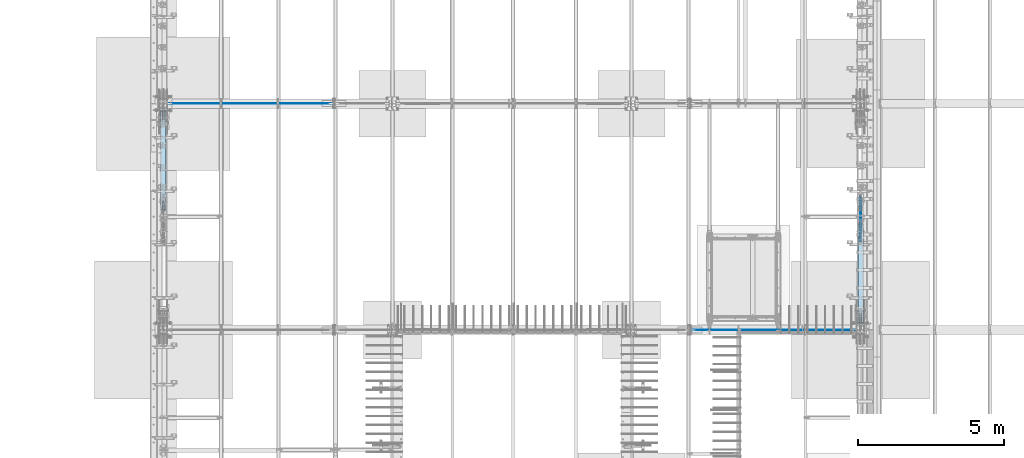
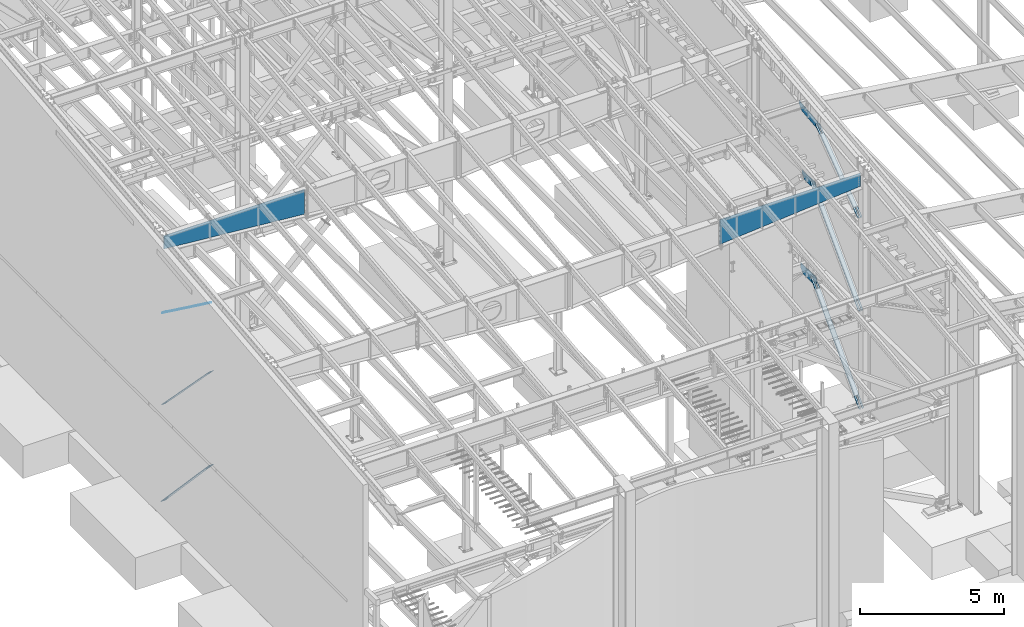
# One storey, part 971 of 1179: 11 plates, 11 elements without a shape of their own.
"""IFC2X3 building model written with IfcOpenShell, lengths in millimetres."""

from ifc_helpers import new_model, si_unit, frame, origin_with_axes, place, context, subcontext, project, spatial, faceted_brep, material, type_object, element, aggregate, save


model = new_model("IFC2X3")

# Units and contexts
model_context = context("Model", 3, precision=1e-05, world=origin_with_axes())
body_context = subcontext(model_context, "Body", "Model", "MODEL_VIEW")
ifc_project = project(units=[si_unit("LENGTHUNIT", "METRE", prefix="MILLI"), si_unit("AREAUNIT", "SQUARE_METRE"), si_unit("VOLUMEUNIT", "CUBIC_METRE"), si_unit("MASSUNIT", "GRAM", prefix="KILO"), si_unit("TIMEUNIT", "SECOND"), si_unit("PLANEANGLEUNIT", "RADIAN"), si_unit("SOLIDANGLEUNIT", "STERADIAN"), si_unit("THERMODYNAMICTEMPERATUREUNIT", "DEGREE_CELSIUS"), si_unit("LUMINOUSINTENSITYUNIT", "LUMEN")], contexts=[model_context])

# Site, building, storey
site_placement = place(None, origin_with_axes())
site = spatial("IfcSite", under=ifc_project, at=site_placement, CompositionType="ELEMENT")
building_placement = place(site_placement, origin_with_axes())
building = spatial("IfcBuilding", under=site, at=building_placement, Name="Undefined", CompositionType="ELEMENT")
storey_placement = place(building_placement, origin_with_axes())
storey = spatial("IfcBuildingStorey", under=building, at=storey_placement, Name="Undefined", CompositionType="ELEMENT", Elevation=0.0)

# Assembly, plate
assembly_1_placement = place(storey_placement, origin_with_axes())
assembly_1 = element("IfcElementAssembly", 1, at=assembly_1_placement, inside=storey, Name="BEAM", AssemblyPlace="NOTDEFINED", PredefinedType="RIGID_FRAME")
ifc_material_1 = material(Name="STEEL/A572-GR.50")
plate_type_1 = type_object("IfcPlateType", PredefinedType="NOTDEFINED")
plate_1_placement = place(assembly_1_placement, frame((24307.8, 14878.05, 7539.60905052728), z_axis=(0.0, 1.0, 0.0), x_axis=(0.0, 0.0, 1.0)))
plate_1 = element("IfcPlate", 2, at=plate_1_placement, type_object=plate_type_1, material=ifc_material_1, Name="PLATE", context=body_context, shape_type="Brep", body=[
    faceted_brep([(0.0, -9.52499999999964, 0.0), (-186.309050642565, -9.52500000000146, 190.890420911079), (-186.309050642565, 9.52500000000146, 190.890420911079), (0.0, 9.52499999999964, 0.0), (-186.30905049287, -9.52500000000146, 482.600000483581), (-186.30905049287, 9.52500000000146, 482.600000483581), (-186.309050331894, -9.52500000000146, 761.609579128339), (-186.309050331894, 9.52500000000146, 761.609579128339), (6.76212039252277e-07, -9.52500000000146, 952.499999997119), (6.76212039252277e-07, 9.52500000000146, 952.499999997119), (143.89094955044, -9.52500000000146, 952.500000233997), (143.89094955044, 9.52500000000146, 952.500000233997), (143.890949095251, -9.52500000000146, 0.0), (143.890949095251, 9.52500000000146, 0.0)], [[[0, 1, 2, 3]], [[1, 4, 5, 2]], [[4, 6, 7, 5]], [[6, 8, 9, 7]], [[8, 10, 11, 9]], [[10, 12, 13, 11]], [[12, 0, 3, 13]], [[5, 7, 9, 11, 13, 3, 2]], [[12, 10, 8, 6, 4, 1, 0]]]),
])
aggregate(assembly_1, [plate_1])

assembly_2_placement = place(storey_placement, origin_with_axes())
assembly_2 = element("IfcElementAssembly", 3, at=assembly_2_placement, inside=storey, Name="CB", AssemblyPlace="NOTDEFINED", PredefinedType="RIGID_FRAME")
ifc_material_2 = material(Name="STEEL/A36")
plate_type_2 = type_object("IfcPlateType", PredefinedType="NOTDEFINED")
plate_2_placement = place(assembly_2_placement, frame((341.312500000002, 18933.9952053959, 8077.03322244691), z_axis=(0.0, -0.806043266248582, 0.591856615182527), x_axis=(1.0, 0.0, 0.0)))
plate_2 = element("IfcPlate", 4, at=plate_2_placement, type_object=plate_type_2, material=ifc_material_2, Name="CB", context=body_context, shape_type="Brep", body=[
    faceted_brep([(0.0, -6.34999999991851, 71.4374999999018), (0.0, -6.35000000333093, 3879.50747780775), (0.0, 6.34999999666252, 3879.50747780777), (0.0, 6.35000000007858, 71.4374999999018), (5.43785589622496, -6.3500000033564, 3906.84542550735), (5.43785589622496, 6.34999999664069, 3906.84542550736), (20.923559318986, -6.35000000337459, 3930.0214184888), (20.923559318986, 6.34999999661886, 3930.02141848881), (44.0995523004189, -6.3500000033855, 3945.50712191157), (44.0995523004189, 6.34999999660431, 3945.50712191158), (71.4375, -6.35000000339278, 3950.9449778078), (71.4375, 6.34999999660431, 3950.94497780781), (71.4375, -6.35000000303262, 3531.22248890774), (71.4375, 6.34999999696083, 3531.22248890776), (109.537499999999, -6.35000000303262, 3531.22248890774), (109.537499999999, 6.34999999696083, 3531.22248890776), (109.537499999999, -6.35000000339278, 3950.9449778078), (109.537499999999, 6.34999999660431, 3950.94497780781), (136.87544769958, -6.3500000033855, 3945.50712191157), (136.87544769958, 6.34999999660431, 3945.50712191158), (160.051440681012, -6.35000000337459, 3930.0214184888), (160.051440681012, 6.34999999661886, 3930.02141848881), (175.537144103774, -6.3500000033564, 3906.84542550735), (175.537144103774, 6.34999999664069, 3906.84542550736), (180.974999999999, -6.35000000333093, 3879.50747780775), (180.974999999999, 6.34999999666252, 3879.50747780777), (180.975000000006, -6.34999999991851, 71.4374999999018), (180.975000000006, 6.35000000007858, 71.4374999999018), (175.537144103779, -6.34999999995125, 44.0995523003585), (175.537144103779, 6.35000000004584, 44.0995523003585), (160.051440681018, -6.34999999997672, 20.9235593189551), (160.051440681018, 6.35000000002401, 20.9235593189587), (136.875447699589, -6.34999999999491, 5.43785589621984), (136.875447699589, 6.35000000000218, 5.43785589621621), (109.537500000006, -6.34999999999854, 3.63797880709171e-12), (109.537500000006, 6.35000000000218, 0.0), (109.537500000006, -6.34999999953288, 419.722488898133), (109.537500000006, 6.35000000046784, 419.722488898133), (71.4375, -6.34999999953288, 419.722488898133), (71.4375, 6.35000000046784, 419.722488898133), (71.4375, -6.34999999999854, 3.63797880709171e-12), (71.4375, 6.35000000000218, 0.0), (44.0995523004167, -6.34999999999491, 5.43785589621984), (44.0995523004167, 6.35000000000218, 5.43785589621621), (20.9235593189878, -6.34999999997672, 20.9235593189551), (20.9235593189878, 6.35000000002401, 20.9235593189587), (5.43785589622712, -6.34999999995125, 44.0995523003585), (5.43785589622712, 6.35000000004584, 44.0995523003585)], [[[0, 1, 2, 3]], [[1, 4, 5, 2]], [[4, 6, 7, 5]], [[6, 8, 9, 7]], [[8, 10, 11, 9]], [[10, 12, 13, 11]], [[12, 14, 15, 13]], [[14, 16, 17, 15]], [[16, 18, 19, 17]], [[18, 20, 21, 19]], [[20, 22, 23, 21]], [[22, 24, 25, 23]], [[24, 26, 27, 25]], [[26, 28, 29, 27]], [[28, 30, 31, 29]], [[30, 32, 33, 31]], [[32, 34, 35, 33]], [[34, 36, 37, 35]], [[36, 38, 39, 37]], [[38, 40, 41, 39]], [[40, 42, 43, 41]], [[42, 44, 45, 43]], [[44, 46, 47, 45]], [[46, 0, 3, 47]], [[5, 7, 9, 11, 13, 15, 17, 19, 21, 23, 25, 27, 29, 31, 33, 35, 37, 39, 41, 43, 45, 47, 3, 2]], [[46, 44, 42, 40, 38, 36, 34, 32, 30, 28, 26, 24, 22, 20, 18, 16, 14, 12, 10, 8, 6, 4, 1, 0]]]),
])
aggregate(assembly_2, [plate_2])

assembly_3_placement = place(storey_placement, origin_with_axes())
assembly_3 = element("IfcElementAssembly", 5, at=assembly_3_placement, inside=storey, Name="CB", AssemblyPlace="NOTDEFINED", PredefinedType="RIGID_FRAME")
plate_3_placement = place(assembly_3_placement, frame((24398.2875, 11774.6044507526, 8077.03369074042), z_axis=(0.0, 0.806042322895357, 0.591857899923163), x_axis=(-1.0, 0.0, 0.0)))
plate_3 = element("IfcPlate", 6, at=plate_3_placement, type_object=plate_type_2, material=ifc_material_2, Name="CB", context=body_context, shape_type="Brep", body=[
    faceted_brep([(0.0, -6.34999999991851, 71.4374999999018), (0.0, -6.34999999920291, 3657.25747777707), (0.0, 6.3500000008051, 3657.25747777707), (0.0, 6.35000000007858, 71.4374999999018), (5.43785589622496, -6.34999999919745, 3684.59542547663), (5.43785589622496, 6.35000000080873, 3684.59542547663), (20.923559318986, -6.34999999919199, 3707.77141845805), (20.923559318986, 6.35000000081419, 3707.77141845804), (44.0995523004189, -6.34999999919017, 3723.2571218808), (44.0995523004189, 6.35000000081783, 3723.25712188079), (71.4375, -6.34999999918654, 3728.69497777702), (71.4375, 6.35000000081965, 3728.69497777701), (71.4375, -6.34999999927476, 3321.6724888803), (71.4375, 6.3500000007287, 3321.67248888029), (109.537499999999, -6.34999999927476, 3321.6724888803), (109.537499999999, 6.3500000007287, 3321.67248888029), (109.537499999999, -6.34999999918654, 3728.69497777702), (109.537499999999, 6.35000000081965, 3728.69497777701), (136.87544769958, -6.34999999919017, 3723.2571218808), (136.87544769958, 6.35000000081783, 3723.25712188079), (160.051440681013, -6.34999999919199, 3707.77141845805), (160.051440681013, 6.35000000081419, 3707.77141845804), (175.537144103774, -6.34999999919745, 3684.59542547663), (175.537144103774, 6.35000000080873, 3684.59542547663), (180.974999999999, -6.34999999920291, 3657.25747777707), (180.974999999999, 6.3500000008051, 3657.25747777707), (180.975000000006, -6.34999999991851, 71.4374999999018), (180.975000000006, 6.35000000007858, 71.4374999999018), (175.537144103779, -6.34999999995125, 44.0995523003585), (175.537144103779, 6.35000000004584, 44.0995523003585), (160.051440681018, -6.34999999997672, 20.9235593189551), (160.051440681018, 6.35000000002401, 20.9235593189587), (136.875447699589, -6.34999999999491, 5.43785589621984), (136.875447699589, 6.35000000000218, 5.43785589621621), (109.537500000006, -6.34999999999854, 3.63797880709171e-12), (109.537500000006, 6.35000000000218, 0.0), (109.537499999999, -6.34999999991595, 407.022488896726), (109.537499999999, 6.35000000009114, 407.022488896719), (71.4375, -6.34999999991595, 407.022488896726), (71.4375, 6.35000000009114, 407.022488896719), (71.4375, -6.34999999999854, 3.63797880709171e-12), (71.4375, 6.35000000000218, 0.0), (44.0995523004167, -6.34999999999491, 5.43785589621984), (44.0995523004167, 6.35000000000218, 5.43785589621621), (20.9235593189878, -6.34999999997672, 20.9235593189551), (20.9235593189878, 6.35000000002401, 20.9235593189587), (5.43785589622712, -6.34999999995125, 44.0995523003585), (5.43785589622712, 6.35000000004584, 44.0995523003585)], [[[0, 1, 2, 3]], [[1, 4, 5, 2]], [[4, 6, 7, 5]], [[6, 8, 9, 7]], [[8, 10, 11, 9]], [[10, 12, 13, 11]], [[12, 14, 15, 13]], [[14, 16, 17, 15]], [[16, 18, 19, 17]], [[18, 20, 21, 19]], [[20, 22, 23, 21]], [[22, 24, 25, 23]], [[24, 26, 27, 25]], [[26, 28, 29, 27]], [[28, 30, 31, 29]], [[30, 32, 33, 31]], [[32, 34, 35, 33]], [[34, 36, 37, 35]], [[36, 38, 39, 37]], [[38, 40, 41, 39]], [[40, 42, 43, 41]], [[42, 44, 45, 43]], [[44, 46, 47, 45]], [[46, 0, 3, 47]], [[5, 7, 9, 11, 13, 15, 17, 19, 21, 23, 25, 27, 29, 31, 33, 35, 37, 39, 41, 43, 45, 47, 3, 2]], [[46, 44, 42, 40, 38, 36, 34, 32, 30, 28, 26, 24, 22, 20, 18, 16, 14, 12, 10, 8, 6, 4, 1, 0]]]),
])
aggregate(assembly_3, [plate_3])

assembly_4_placement = place(storey_placement, origin_with_axes())
assembly_4 = element("IfcElementAssembly", 7, at=assembly_4_placement, inside=storey, Name="CB", AssemblyPlace="NOTDEFINED", PredefinedType="RIGID_FRAME")
plate_type_3 = type_object("IfcPlateType", PredefinedType="NOTDEFINED")
plate_4_placement = place(assembly_4_placement, frame((338.137500000002, 18978.4459530821, 4148.035704534), z_axis=(0.0, -0.69846692303685, 0.715642339037759), x_axis=(1.0, 0.0, 0.0)))
plate_4 = element("IfcPlate", 8, at=plate_4_placement, type_object=plate_type_3, material=ifc_material_2, Name="CB", context=body_context, shape_type="Brep", body=[
    faceted_brep([(0.0, -9.52500000000691, 71.4375), (0.0, -9.52499999965221, 4791.84892355422), (0.0, 9.52500000033979, 4791.84892355423), (0.0, 9.52500000000327, 71.4374999999909), (5.43785589622496, -9.52499999964857, 4819.1868712538), (5.43785589622496, 9.52500000034343, 4819.18687125381), (20.923559318986, -9.52499999964857, 4842.36286423524), (20.923559318986, 9.52500000034343, 4842.36286423525), (44.0995523004189, -9.52499999964493, 4857.848567658), (44.0995523004189, 9.52500000034343, 4857.84856765801), (71.4375, -9.52499999964493, 4863.28642355423), (71.4375, 9.52500000034706, 4863.28642355424), (71.4375, -9.52499999967404, 4441.70468275449), (71.4375, 9.52500000031432, 4441.7046827545), (115.8875, -9.52499999967404, 4441.70468275449), (115.8875, 9.52500000031432, 4441.7046827545), (115.8875, -9.52499999964493, 4863.28642355423), (115.8875, 9.52500000034706, 4863.28642355424), (143.225447699581, -9.52499999964493, 4857.848567658), (143.225447699581, 9.52500000034343, 4857.84856765801), (166.401440681014, -9.52499999964857, 4842.36286423524), (166.401440681014, 9.52500000034343, 4842.36286423525), (181.887144103775, -9.52499999964857, 4819.1868712538), (181.887144103775, 9.52500000034343, 4819.18687125381), (187.325, -9.52499999965221, 4791.84892355422), (187.325, 9.52500000033979, 4791.84892355423), (187.324999999997, -9.52500000000691, 71.4375), (187.324999999997, 9.52500000000327, 71.4374999999909), (181.88714410377, -9.52500000000691, 44.0995523004203), (181.88714410377, 9.52500000000509, 44.0995523004112), (166.401440681009, -9.52500000000691, 20.9235593189915), (166.401440681009, 9.52500000000509, 20.9235593189787), (143.22544769958, -9.52500000000327, 5.43785589623076), (143.22544769958, 9.52500000000509, 5.43785589621621), (115.887499999997, -9.52500000000509, 5.45696821063757e-12), (115.887499999997, 9.52500000000691, -7.27595761418343e-12), (115.887499999997, -9.52500000001783, 421.581740798863), (115.887499999997, 9.52499999999418, 421.581740798851), (71.4375, -9.52500000001783, 421.581740798863), (71.4375, 9.52499999999418, 421.581740798851), (71.4375, -9.52500000000509, 5.45696821063757e-12), (71.4375, 9.52500000000691, -7.27595761418343e-12), (44.0995523004167, -9.52500000000327, 5.43785589623076), (44.0995523004167, 9.52500000000509, 5.43785589621621), (20.9235593189878, -9.52500000000691, 20.9235593189915), (20.9235593189878, 9.52500000000509, 20.9235593189787), (5.43785589622712, -9.52500000000691, 44.0995523004203), (5.43785589622712, 9.52500000000509, 44.0995523004112)], [[[0, 1, 2, 3]], [[1, 4, 5, 2]], [[4, 6, 7, 5]], [[6, 8, 9, 7]], [[8, 10, 11, 9]], [[10, 12, 13, 11]], [[12, 14, 15, 13]], [[14, 16, 17, 15]], [[16, 18, 19, 17]], [[18, 20, 21, 19]], [[20, 22, 23, 21]], [[22, 24, 25, 23]], [[24, 26, 27, 25]], [[26, 28, 29, 27]], [[28, 30, 31, 29]], [[30, 32, 33, 31]], [[32, 34, 35, 33]], [[34, 36, 37, 35]], [[36, 38, 39, 37]], [[38, 40, 41, 39]], [[40, 42, 43, 41]], [[42, 44, 45, 43]], [[44, 46, 47, 45]], [[46, 0, 3, 47]], [[5, 7, 9, 11, 13, 15, 17, 19, 21, 23, 25, 27, 29, 31, 33, 35, 37, 39, 41, 43, 45, 47, 3, 2]], [[46, 44, 42, 40, 38, 36, 34, 32, 30, 28, 26, 24, 22, 20, 18, 16, 14, 12, 10, 8, 6, 4, 1, 0]]]),
])
aggregate(assembly_4, [plate_4])

assembly_5_placement = place(storey_placement, origin_with_axes())
assembly_5 = element("IfcElementAssembly", 9, at=assembly_5_placement, inside=storey, Name="CB", AssemblyPlace="NOTDEFINED", PredefinedType="RIGID_FRAME")
plate_5_placement = place(assembly_5_placement, frame((24401.4625, 11730.1540473062, 4148.03570415857), z_axis=(0.0, 0.698466923036852, 0.715642339037758), x_axis=(-1.0, 0.0, 0.0)))
plate_5 = element("IfcPlate", 10, at=plate_5_placement, type_object=plate_type_3, material=ifc_material_2, Name="CB", context=body_context, shape_type="Brep", body=[
    faceted_brep([(0.0, -9.52500000000691, 71.4375), (0.0, -9.52499999865904, 4791.85938084953), (0.0, 9.52500000133659, 4791.85938084954), (0.0, 9.52500000000327, 71.4374999999909), (5.43785589622348, -9.52499999864995, 4819.19732854909), (5.43785589622348, 9.52500000134387, 4819.1973285491), (20.9235593189878, -9.52499999864358, 4842.37332153051), (20.9235593189878, 9.52500000135024, 4842.37332153051), (44.0995523004203, -9.52499999863994, 4857.85902495325), (44.0995523004203, 9.5250000013566, 4857.85902495326), (71.4375, -9.52499999863721, 4863.29688084947), (71.4375, 9.52500000135842, 4863.29688084948), (71.4375, -9.52499999875545, 4441.71514005305), (71.4375, 9.5250000012411, 4441.71514005306), (115.887499999997, -9.52499999875545, 4441.71514005305), (115.887499999997, 9.5250000012411, 4441.71514005306), (115.887499999997, -9.52499999863721, 4863.29688084947), (115.887499999997, 9.52500000135842, 4863.29688084948), (143.225447699577, -9.52499999863994, 4857.85902495325), (143.225447699577, 9.5250000013566, 4857.85902495326), (166.401440681009, -9.52499999864358, 4842.37332153051), (166.401440681009, 9.52500000135024, 4842.37332153051), (181.887144103774, -9.52499999864995, 4819.19732854909), (181.887144103774, 9.52500000134387, 4819.1973285491), (187.324999999997, -9.52499999865904, 4791.85938084953), (187.324999999997, 9.52500000133659, 4791.85938084954), (187.324999999997, -9.52500000000691, 71.4375), (187.324999999997, 9.52500000000327, 71.4374999999909), (181.88714410377, -9.52500000000691, 44.0995523004203), (181.88714410377, 9.52500000000509, 44.0995523004112), (166.401440681009, -9.52500000000691, 20.9235593189915), (166.401440681009, 9.52500000000509, 20.9235593189787), (143.22544769958, -9.52500000000327, 5.43785589623076), (143.22544769958, 9.52500000000509, 5.43785589621621), (115.887499999997, -9.52500000000509, 5.45696821063757e-12), (115.887499999997, 9.52500000000691, -7.27595761418343e-12), (115.887499999997, -9.52500000001783, 421.581740798863), (115.887499999997, 9.52499999999418, 421.581740798851), (71.4375, -9.52500000001783, 421.581740798863), (71.4375, 9.52499999999418, 421.581740798851), (71.4375, -9.52500000000509, 5.45696821063757e-12), (71.4375, 9.52500000000691, -7.27595761418343e-12), (44.0995523004167, -9.52500000000327, 5.43785589623076), (44.0995523004167, 9.52500000000509, 5.43785589621621), (20.9235593189878, -9.52500000000691, 20.9235593189915), (20.9235593189878, 9.52500000000509, 20.9235593189787), (5.43785589622712, -9.52500000000691, 44.0995523004203), (5.43785589622712, 9.52500000000509, 44.0995523004112)], [[[0, 1, 2, 3]], [[1, 4, 5, 2]], [[4, 6, 7, 5]], [[6, 8, 9, 7]], [[8, 10, 11, 9]], [[10, 12, 13, 11]], [[12, 14, 15, 13]], [[14, 16, 17, 15]], [[16, 18, 19, 17]], [[18, 20, 21, 19]], [[20, 22, 23, 21]], [[22, 24, 25, 23]], [[24, 26, 27, 25]], [[26, 28, 29, 27]], [[28, 30, 31, 29]], [[30, 32, 33, 31]], [[32, 34, 35, 33]], [[34, 36, 37, 35]], [[36, 38, 39, 37]], [[38, 40, 41, 39]], [[40, 42, 43, 41]], [[42, 44, 45, 43]], [[44, 46, 47, 45]], [[46, 0, 3, 47]], [[5, 7, 9, 11, 13, 15, 17, 19, 21, 23, 25, 27, 29, 31, 33, 35, 37, 39, 41, 43, 45, 47, 3, 2]], [[46, 44, 42, 40, 38, 36, 34, 32, 30, 28, 26, 24, 22, 20, 18, 16, 14, 12, 10, 8, 6, 4, 1, 0]]]),
])
aggregate(assembly_5, [plate_5])

assembly_6_placement = place(storey_placement, origin_with_axes())
assembly_6 = element("IfcElementAssembly", 11, at=assembly_6_placement, inside=storey, Name="BEAM", AssemblyPlace="NOTDEFINED", PredefinedType="RIGID_FRAME")
plate_type_4 = type_object("IfcPlateType", PredefinedType="NOTDEFINED")
plate_6_placement = place(assembly_6_placement, frame((24307.8, 14793.6602577624, 3473.77993843472), z_axis=(0.0, 1.0, 0.0), x_axis=(0.0, 0.0, 1.0)))
plate_6 = element("IfcPlate", 12, at=plate_6_placement, type_object=plate_type_4, material=ifc_material_1, Name="PLATE", context=body_context, shape_type="Brep", body=[
    faceted_brep([(0.0, -12.7, 0.0), (-165.530801027491, -12.7, 175.571193903201), (-165.530801027491, 12.7, 175.571193903201), (0.0, 12.7, 0.0), (-165.530801027491, -12.7, 566.989741928064), (-165.530801027491, 12.7, 566.989741928064), (-165.530801027491, -12.7, 945.708290572049), (-165.530801027491, 12.7, 945.708290572049), (-3.09023562294897e-07, -12.7, 1121.27948414748), (-3.09023562294897e-07, 12.7, 1121.27948414748), (209.22006156528, -12.7, 1121.27948414748), (209.22006156528, 12.7, 1121.27948414748), (209.22006156528, -12.7, -3.63797880709171e-12), (209.22006156528, 12.7, -3.63797880709171e-12)], [[[0, 1, 2, 3]], [[1, 4, 5, 2]], [[4, 6, 7, 5]], [[6, 8, 9, 7]], [[8, 10, 11, 9]], [[10, 12, 13, 11]], [[12, 0, 3, 13]], [[5, 7, 9, 11, 13, 3, 2]], [[12, 10, 8, 6, 4, 1, 0]]]),
])
aggregate(assembly_6, [plate_6])

assembly_7_placement = place(storey_placement, origin_with_axes())
assembly_7 = element("IfcElementAssembly", 13, at=assembly_7_placement, inside=storey, Name="BEAM", AssemblyPlace="NOTDEFINED", PredefinedType="RIGID_FRAME")
plate_type_5 = type_object("IfcPlateType", PredefinedType="NOTDEFINED")
plate_7_placement = place(assembly_7_placement, frame((24307.8, 14510.7798598646, 10333.8083689834), z_axis=(0.0, 0.993676146336441, 0.112284087038017), x_axis=(0.0, 0.112284087038014, -0.993676146336441)))
plate_7 = element("IfcPlate", 14, at=plate_7_placement, type_object=plate_type_5, material=ifc_material_1, Name="PLATE", context=body_context, shape_type="Brep", body=[
    faceted_brep([(0.0, -9.52499999999964, 0.0), (-1.09139364212751e-11, -9.52500000000146, 1514.92312530976), (-1.09139364212751e-11, 9.52500000000146, 1514.92312530976), (0.0, 9.52499999999964, 0.0), (107.456778456453, -9.52500000000146, 1514.92312530977), (107.456778456453, 9.52500000000146, 1514.92312530977), (302.948908599677, -9.52500000000146, 1334.300867366), (302.948908599677, 9.52500000000146, 1334.300867366), (302.948908599677, -9.52500000000146, 886.273126128986), (302.948908599677, 9.52500000000146, 886.273126128986), (302.948908599679, -9.52500000000146, 118.410705535174), (302.948908599679, 9.52500000000146, 118.410705535174), (96.5428308297123, -9.52500000000146, 1.81898940354586e-12), (96.5428308297123, 9.52500000000146, 1.81898940354586e-12)], [[[0, 1, 2, 3]], [[1, 4, 5, 2]], [[4, 6, 7, 5]], [[6, 8, 9, 7]], [[8, 10, 11, 9]], [[10, 12, 13, 11]], [[12, 0, 3, 13]], [[5, 7, 9, 11, 13, 3, 2]], [[12, 10, 8, 6, 4, 1, 0]]]),
])
aggregate(assembly_7, [plate_7])

assembly_8_placement = place(storey_placement, origin_with_axes())
assembly_8 = element("IfcElementAssembly", 15, at=assembly_8_placement, inside=storey, Name="CB", AssemblyPlace="NOTDEFINED", PredefinedType="RIGID_FRAME")
plate_type_6 = type_object("IfcPlateType", PredefinedType="NOTDEFINED")
plate_8_placement = place(assembly_8_placement, frame((336.550000000002, 19018.1469828896, 6.46967490713075), z_axis=(0.0, -0.68599585875867, 0.727605443744036), x_axis=(1.0, 0.0, 0.0)))
plate_8 = element("IfcPlate", 16, at=plate_8_placement, type_object=plate_type_6, material=ifc_material_2, Name="CB", context=body_context, shape_type="Brep", body=[
    faceted_brep([(0.0, -12.700000000139, 66.6750030518815), (0.0, -12.7000000021235, 4899.51727466588), (0.0, 12.6999999978489, 4899.5172746659), (0.0, 12.6999999998006, 66.6750030519361), (5.0753324021112, -12.7000000021344, 4925.03269368669), (5.0753324021112, 12.6999999978379, 4925.03269368671), (19.5286562582261, -12.7000000021453, 4946.66362145943), (19.5286562582261, 12.699999997827, 4946.66362145945), (41.1595840309583, -12.7000000021508, 4961.11694531555), (41.1595840309583, 12.6999999978198, 4961.11694531558), (66.675, -12.7000000021526, 4966.19227771766), (66.675, 12.6999999978179, 4966.19227771769), (66.675, -12.7000000019343, 4467.47113886627), (66.675, 12.6999999980362, 4467.4711388663), (123.825, -12.7000000019343, 4467.47113886627), (123.825, 12.6999999980362, 4467.4711388663), (123.824996948242, -12.7000000021526, 4966.19227771766), (123.824996948242, 12.6999999978179, 4966.19227771769), (149.340415969042, -12.7000000021508, 4961.11694531555), (149.340415969042, 12.6999999978198, 4961.11694531558), (170.971343741774, -12.7000000021453, 4946.66362145943), (170.971343741774, 12.699999997827, 4946.66362145945), (185.424667597889, -12.7000000021344, 4925.03269368669), (185.424667597889, 12.6999999978379, 4925.03269368671), (190.5, -12.7000000021235, 4899.51727466588), (190.5, 12.6999999978489, 4899.5172746659), (190.5, -12.700000000139, 66.6750030518815), (190.5, 12.6999999998006, 66.6750030519361), (185.424667597889, -12.7000000000735, 41.159584031022), (185.424667597889, 12.6999999998661, 41.1595840310729), (170.971343741774, -12.7000000000189, 19.5286562582405), (170.971343741774, 12.6999999999171, 19.5286562582951), (149.340415969042, -12.6999999999825, 5.07533240209159), (149.340415969042, 12.6999999999571, 5.07533240214616), (123.824999618709, -12.7000000000002, 0.0), (123.8249996187, 12.6999999999996, 0.0), (123.825, -12.7000000002045, 498.721138851377), (123.825, 12.6999999997697, 498.721138851402), (66.675, -12.7000000002045, 498.721138851377), (66.675, 12.6999999997697, 498.721138851402), (66.6750030517578, -12.699999999968, -2.91038304567337e-11), (66.6750030517578, 12.699999999968, 2.91038304567337e-11), (41.1595840309583, -12.6999999999825, 5.07533240209159), (41.1595840309583, 12.6999999999571, 5.07533240214616), (19.5286562582261, -12.7000000000189, 19.5286562582405), (19.5286562582261, 12.6999999999171, 19.5286562582951), (5.0753324021112, -12.7000000000735, 41.159584031022), (5.0753324021112, 12.6999999998661, 41.1595840310729)], [[[0, 1, 2, 3]], [[1, 4, 5, 2]], [[4, 6, 7, 5]], [[6, 8, 9, 7]], [[8, 10, 11, 9]], [[10, 12, 13, 11]], [[12, 14, 15, 13]], [[14, 16, 17, 15]], [[16, 18, 19, 17]], [[18, 20, 21, 19]], [[20, 22, 23, 21]], [[22, 24, 25, 23]], [[24, 26, 27, 25]], [[26, 28, 29, 27]], [[28, 30, 31, 29]], [[30, 32, 33, 31]], [[32, 34, 35, 33]], [[34, 36, 37, 35]], [[36, 38, 39, 37]], [[38, 40, 41, 39]], [[40, 42, 43, 41]], [[42, 44, 45, 43]], [[44, 46, 47, 45]], [[46, 0, 3, 47]], [[5, 7, 9, 11, 13, 15, 17, 19, 21, 23, 25, 27, 29, 31, 33, 35, 37, 39, 41, 43, 45, 47, 3, 2]], [[46, 44, 42, 40, 38, 36, 34, 32, 30, 28, 26, 24, 22, 20, 18, 16, 14, 12, 10, 8, 6, 4, 1, 0]]]),
])
aggregate(assembly_8, [plate_8])

assembly_9_placement = place(storey_placement, origin_with_axes())
assembly_9 = element("IfcElementAssembly", 17, at=assembly_9_placement, inside=storey, Name="CB", AssemblyPlace="NOTDEFINED", PredefinedType="RIGID_FRAME")
plate_9_placement = place(assembly_9_placement, frame((24403.05, 11690.4530167881, 6.46967521355373), z_axis=(0.0, 0.685995858758672, 0.727605443744034), x_axis=(-1.0, 0.0, 0.0)))
plate_9 = element("IfcPlate", 18, at=plate_9_placement, type_object=plate_type_6, material=ifc_material_2, Name="CB", context=body_context, shape_type="Brep", body=[
    faceted_brep([(0.0, -12.700000000139, 66.6750030518815), (0.0, -12.7000000021235, 4899.51727466588), (0.0, 12.6999999978489, 4899.5172746659), (0.0, 12.6999999998006, 66.6750030519361), (5.0753324021112, -12.7000000021344, 4925.03269368669), (5.0753324021112, 12.6999999978379, 4925.03269368671), (19.5286562582261, -12.7000000021453, 4946.66362145943), (19.5286562582261, 12.699999997827, 4946.66362145945), (41.1595840309583, -12.7000000021508, 4961.11694531555), (41.1595840309583, 12.6999999978198, 4961.11694531558), (66.675, -12.7000000021526, 4966.19227771766), (66.675, 12.6999999978179, 4966.19227771769), (66.675, -12.7000000019343, 4467.47113886627), (66.675, 12.6999999980362, 4467.4711388663), (123.825, -12.7000000019343, 4467.47113886627), (123.825, 12.6999999980362, 4467.4711388663), (123.824996948242, -12.7000000021526, 4966.19227771766), (123.824996948242, 12.6999999978179, 4966.19227771769), (149.340415969042, -12.7000000021508, 4961.11694531555), (149.340415969042, 12.6999999978198, 4961.11694531558), (170.971343741774, -12.7000000021453, 4946.66362145943), (170.971343741774, 12.699999997827, 4946.66362145945), (185.424667597889, -12.7000000021344, 4925.03269368669), (185.424667597889, 12.6999999978379, 4925.03269368671), (190.5, -12.7000000021235, 4899.51727466588), (190.5, 12.6999999978489, 4899.5172746659), (190.5, -12.700000000139, 66.6750030518815), (190.5, 12.6999999998006, 66.6750030519361), (185.424667597889, -12.7000000000735, 41.159584031022), (185.424667597889, 12.6999999998661, 41.1595840310729), (170.971343741774, -12.7000000000189, 19.5286562582405), (170.971343741774, 12.6999999999171, 19.5286562582951), (149.340415969042, -12.6999999999825, 5.07533240209159), (149.340415969042, 12.6999999999571, 5.07533240214616), (123.824999618709, -12.7000000000002, 0.0), (123.8249996187, 12.6999999999996, 0.0), (123.825, -12.7000000002045, 498.721138851377), (123.825, 12.6999999997697, 498.721138851402), (66.675, -12.7000000002045, 498.721138851377), (66.675, 12.6999999997697, 498.721138851402), (66.6750030517578, -12.699999999968, -2.91038304567337e-11), (66.6750030517578, 12.699999999968, 2.91038304567337e-11), (41.1595840309583, -12.6999999999825, 5.07533240209159), (41.1595840309583, 12.6999999999571, 5.07533240214616), (19.5286562582261, -12.7000000000189, 19.5286562582405), (19.5286562582261, 12.6999999999171, 19.5286562582951), (5.0753324021112, -12.7000000000735, 41.159584031022), (5.0753324021112, 12.6999999998661, 41.1595840310729)], [[[0, 1, 2, 3]], [[1, 4, 5, 2]], [[4, 6, 7, 5]], [[6, 8, 9, 7]], [[8, 10, 11, 9]], [[10, 12, 13, 11]], [[12, 14, 15, 13]], [[14, 16, 17, 15]], [[16, 18, 19, 17]], [[18, 20, 21, 19]], [[20, 22, 23, 21]], [[22, 24, 25, 23]], [[24, 26, 27, 25]], [[26, 28, 29, 27]], [[28, 30, 31, 29]], [[30, 32, 33, 31]], [[32, 34, 35, 33]], [[34, 36, 37, 35]], [[36, 38, 39, 37]], [[38, 40, 41, 39]], [[40, 42, 43, 41]], [[42, 44, 45, 43]], [[44, 46, 47, 45]], [[46, 0, 3, 47]], [[5, 7, 9, 11, 13, 15, 17, 19, 21, 23, 25, 27, 29, 31, 33, 35, 37, 39, 41, 43, 45, 47, 3, 2]], [[46, 44, 42, 40, 38, 36, 34, 32, 30, 28, 26, 24, 22, 20, 18, 16, 14, 12, 10, 8, 6, 4, 1, 0]]]),
])
aggregate(assembly_9, [plate_9])

assembly_10_placement = place(storey_placement, origin_with_axes())
assembly_10 = element("IfcElementAssembly", 19, at=assembly_10_placement, inside=storey, Name="RAFTER BEAM", AssemblyPlace="NOTDEFINED", PredefinedType="RIGID_FRAME")
plate_type_7 = type_object("IfcPlateType", PredefinedType="NOTDEFINED")
plate_10_placement = place(assembly_10_placement, frame((24137.938, 11480.8093353614, 10229.8713571015), z_axis=(0.0, 0.0, -1.0), x_axis=(-1.0, 0.0, 0.0)))
plate_10 = element("IfcPlate", 20, at=plate_10_placement, type_object=plate_type_7, material=ifc_material_2, Name="RAFTER BEAM", context=body_context, shape_type="Brep", body=[
    faceted_brep([(0.0, -7.9375, 0.0), (0.000499699228384998, -7.9375, 565.069756066781), (0.000499699228384998, 7.9375, 565.069756066781), (0.0, 7.9375, 0.0), (5646.73800009591, -7.9375, 1059.81203939609), (5646.73800009591, 7.9375, 1059.81203939609), (5646.73800009591, 7.9375, -2.80124368146062e-10), (5646.73800009591, -7.9375, -2.80124368146062e-10)], [[[0, 1, 2, 3]], [[2, 1, 4, 5]], [[3, 2, 5, 6]], [[0, 3, 6, 7]], [[1, 0, 7, 4]], [[6, 5, 4, 7]]]),
])
aggregate(assembly_10, [plate_10])

assembly_11_placement = place(storey_placement, origin_with_axes())
assembly_11 = element("IfcElementAssembly", 21, at=assembly_11_placement, inside=storey, Name="RAFTER BEAM", AssemblyPlace="NOTDEFINED", PredefinedType="RIGID_FRAME")
plate_11_placement = place(assembly_11_placement, frame((6273.8, 19227.7999999987, 11105.3562496185), z_axis=(0.0, 0.0, -1.0), x_axis=(-1.0, 0.0, 0.0)))
plate_11 = element("IfcPlate", 22, at=plate_11_placement, type_object=plate_type_7, material=ifc_material_2, Name="RAFTER BEAM", context=body_context, shape_type="Brep", body=[
    faceted_brep([(5672.13750000165, -7.9375, 565.069754352626), (5672.1375, -7.9375, 0.0), (5672.1375, 7.9375, 0.0), (5672.13750000165, 7.9375, 565.069754352626), (25.4000000002561, -7.9375, 1059.81203938672), (25.4000000002561, -7.9375, 0.0), (25.4000000002561, 7.9375, 0.0), (25.4000000002561, 7.9375, 1059.81203938672)], [[[0, 1, 2, 3]], [[1, 0, 4, 5]], [[2, 1, 5, 6]], [[3, 2, 6, 7]], [[0, 3, 7, 4]], [[6, 5, 4, 7]]]),
])
aggregate(assembly_11, [plate_11])

save(model, "model.ifc")
